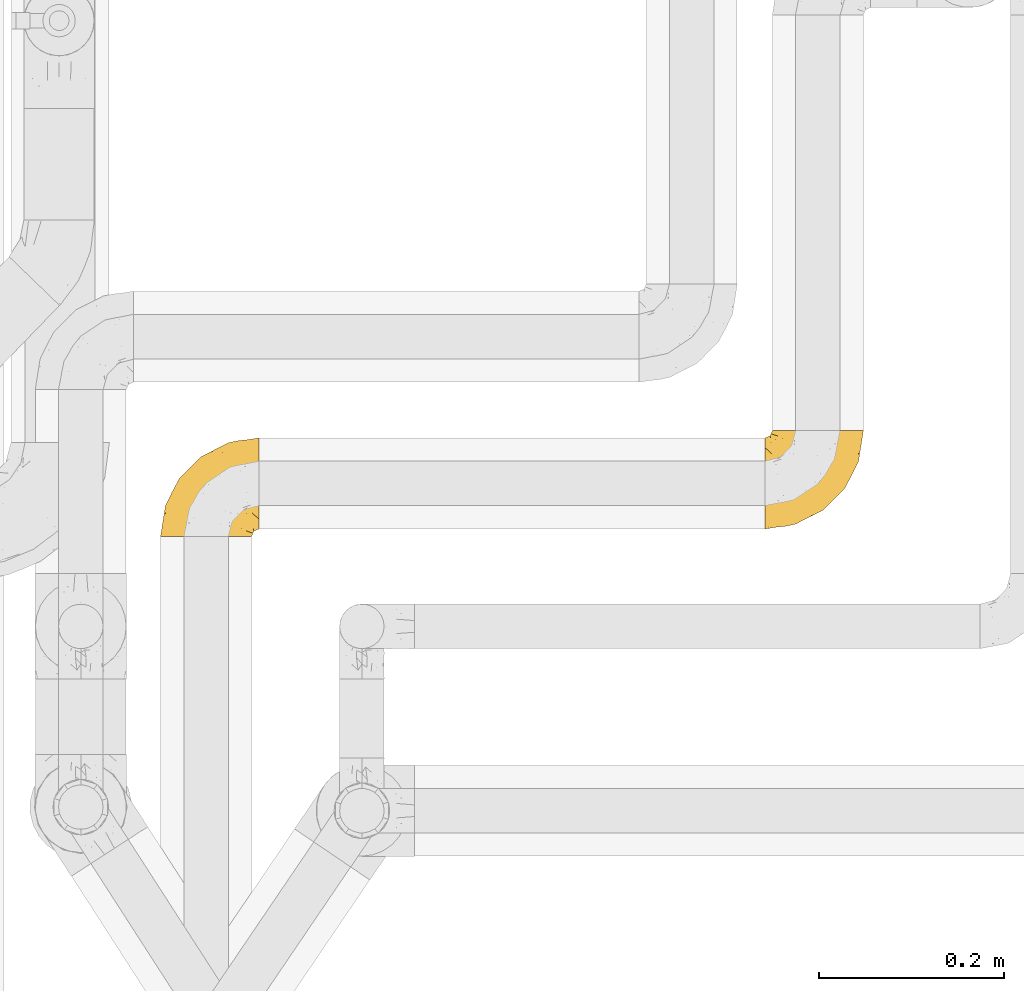
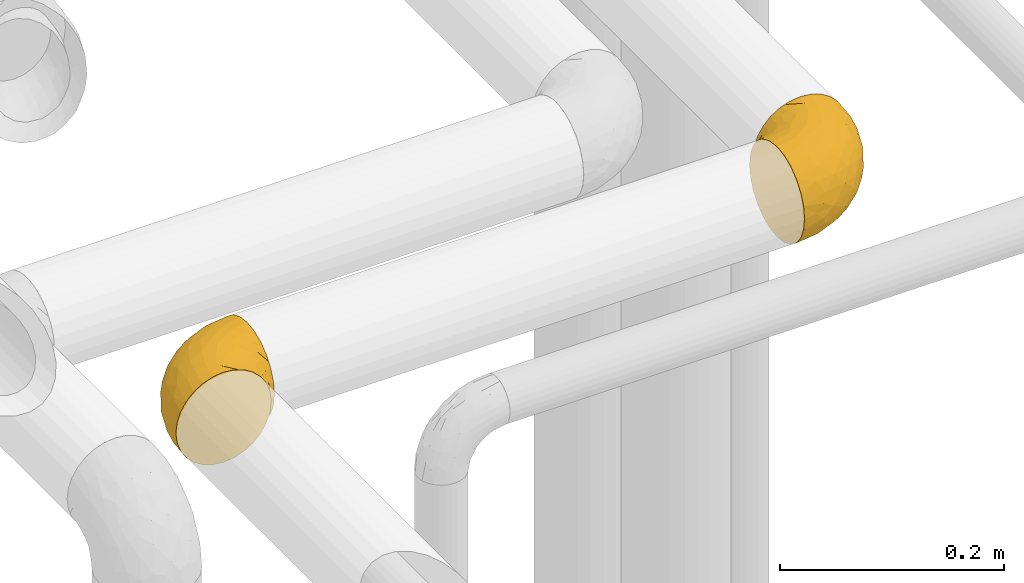
# One storey, part 399 of 827: 2 coverings.
"""IFC2X3 building model written with IfcOpenShell, lengths in millimetres."""

from ifc_helpers import new_model, entity, si_unit, converted_unit, derived_unit, direction, frame, origin, place, context, subcontext, project, spatial, faceted_brep, element, save


model = new_model("IFC2X3")

# Units and contexts
model_context = context("Model", 3, precision=0.01, world=origin(), true_north=direction((6.12303176911189e-17, 1.0)))
body_context = subcontext(model_context, "Body", "Model", "MODEL_VIEW")
ifc_project = project(units=[si_unit("LENGTHUNIT", "METRE", prefix="MILLI"), si_unit("AREAUNIT", "SQUARE_METRE"), si_unit("VOLUMEUNIT", "CUBIC_METRE"), converted_unit("PLANEANGLEUNIT", "DEGREE", entity("IfcRatioMeasure", 0.0174532925199433), si_unit("PLANEANGLEUNIT", "RADIAN"), dimensions=[0, 0, 0, 0, 0, 0, 0]), si_unit("MASSUNIT", "GRAM", prefix="KILO"), derived_unit("MASSDENSITYUNIT", [(si_unit("MASSUNIT", "GRAM", prefix="KILO"), 1), (si_unit("LENGTHUNIT", "METRE"), -3)]), derived_unit("MOMENTOFINERTIAUNIT", [(si_unit("LENGTHUNIT", "METRE"), 4)]), si_unit("TIMEUNIT", "SECOND"), si_unit("FREQUENCYUNIT", "HERTZ"), si_unit("THERMODYNAMICTEMPERATUREUNIT", "DEGREE_CELSIUS"), derived_unit("THERMALTRANSMITTANCEUNIT", [(si_unit("MASSUNIT", "GRAM", prefix="KILO"), 1), (si_unit("THERMODYNAMICTEMPERATUREUNIT", "KELVIN"), -1), (si_unit("TIMEUNIT", "SECOND"), -3)]), derived_unit("VOLUMETRICFLOWRATEUNIT", [(si_unit("LENGTHUNIT", "METRE"), 3), (si_unit("TIMEUNIT", "SECOND"), -1)]), derived_unit("MASSFLOWRATEUNIT", [(si_unit("MASSUNIT", "GRAM", prefix="KILO"), 1), (si_unit("TIMEUNIT", "SECOND"), -1)]), derived_unit("ROTATIONALFREQUENCYUNIT", [(si_unit("TIMEUNIT", "SECOND"), -1)]), si_unit("ELECTRICCURRENTUNIT", "AMPERE"), si_unit("ELECTRICVOLTAGEUNIT", "VOLT"), si_unit("POWERUNIT", "WATT"), si_unit("FORCEUNIT", "NEWTON", prefix="KILO"), si_unit("ILLUMINANCEUNIT", "LUX"), si_unit("LUMINOUSFLUXUNIT", "LUMEN"), si_unit("LUMINOUSINTENSITYUNIT", "CANDELA"), derived_unit("USERDEFINED", [(si_unit("MASSUNIT", "GRAM", prefix="KILO"), -1), (si_unit("LENGTHUNIT", "METRE"), -2), (si_unit("TIMEUNIT", "SECOND"), 3), (si_unit("LUMINOUSFLUXUNIT", "LUMEN"), 1)]), derived_unit("LINEARVELOCITYUNIT", [(si_unit("LENGTHUNIT", "METRE"), 1), (si_unit("TIMEUNIT", "SECOND"), -1)]), si_unit("PRESSUREUNIT", "PASCAL"), derived_unit("USERDEFINED", [(si_unit("LENGTHUNIT", "METRE"), -2), (si_unit("MASSUNIT", "GRAM", prefix="KILO"), 1), (si_unit("TIMEUNIT", "SECOND"), -2)]), derived_unit("LINEARFORCEUNIT", [(si_unit("MASSUNIT", "GRAM", prefix="KILO"), 1), (si_unit("LENGTHUNIT", "METRE"), 1), (si_unit("TIMEUNIT", "SECOND"), -2), (si_unit("LENGTHUNIT", "METRE"), -1)]), derived_unit("PLANARFORCEUNIT", [(si_unit("MASSUNIT", "GRAM", prefix="KILO"), 1), (si_unit("LENGTHUNIT", "METRE"), 1), (si_unit("TIMEUNIT", "SECOND"), -2), (si_unit("LENGTHUNIT", "METRE"), -2)])], contexts=[model_context])

# Site, building, storey
site_placement = place(None, origin())
site = spatial("IfcSite", under=ifc_project, at=site_placement, CompositionType="ELEMENT")
building_placement = place(site_placement, origin())
building = spatial("IfcBuilding", under=site, at=building_placement, CompositionType="ELEMENT")
storey_placement = place(building_placement, frame((0.0, 0.0, 28200.0)))
storey = spatial("IfcBuildingStorey", under=building, at=storey_placement, Name="08", CompositionType="ELEMENT", Elevation=28200.0)

# Coverings
covering_1_placement = place(storey_placement, frame((47429.4, 14538.0, 2949.25)))
element("IfcCovering", 1, at=covering_1_placement, inside=storey, Name=":ADSK_", ObjectType=":ADSK_", PredefinedType="INSULATION", context=body_context, shape_type="Brep", body=[
    faceted_brep([(58.6, 107.75, 99.9), (69.54, 107.75, 98.66), (79.93, 107.75, 95.02), (89.25, 107.75, 89.17), (97.03, 107.75, 81.38), (102.88, 107.75, 72.06), (106.51, 107.75, 61.68), (107.75, 107.75, 50.75), (106.51, 107.75, 39.8), (102.87, 107.75, 29.41), (97.02, 107.75, 20.09), (89.23, 107.75, 12.31), (79.91, 107.75, 6.46), (69.53, 107.75, 2.83), (58.6, 107.75, 1.6), (52.89, 107.75, 2.24), (47.65, 107.75, 2.83), (42.46, 107.75, 4.65), (37.26, 107.75, 6.47), (27.94, 107.75, 12.32), (20.16, 107.75, 20.11), (14.31, 107.75, 29.43), (10.68, 107.75, 39.81), (9.45, 107.75, 50.75), (10.68, 107.75, 61.69), (14.32, 107.75, 72.08), (20.17, 107.75, 81.4), (27.96, 107.75, 89.18), (37.28, 107.75, 95.03), (42.47, 107.75, 96.85), (47.66, 107.75, 98.66), (52.89, 107.75, 99.25), (55.75, 107.75, 99.57), (1.6, 98.22, 38.02), (1.6, 93.31, 26.17), (1.6, 89.4, 21.08), (1.6, 85.5, 15.99), (1.6, 80.41, 12.09), (1.6, 75.32, 8.18), (1.6, 69.39, 5.73), (1.6, 63.47, 3.27), (1.6, 56.48, 2.35), (1.6, 53.61, 1.97), (1.6, 50.75, 1.6), (1.6, 38.02, 3.27), (1.6, 26.17, 8.18), (1.6, 15.99, 15.99), (1.6, 8.18, 26.17), (1.6, 3.27, 38.02), (1.6, 1.6, 50.75), (1.6, 3.27, 63.47), (1.6, 8.18, 75.32), (1.6, 15.99, 85.5), (1.6, 26.17, 93.31), (1.6, 38.02, 98.22), (1.6, 50.75, 99.9), (1.6, 56.48, 99.14), (1.6, 63.47, 98.22), (1.6, 69.39, 95.77), (1.6, 75.32, 93.31), (1.6, 80.41, 89.4), (1.6, 85.5, 85.5), (1.6, 89.4, 80.41), (1.6, 93.31, 75.32), (1.6, 98.22, 63.47), (1.6, 99.9, 50.75), (69.96, 27.53, 59.31), (59.59, 25.32, 73.08), (51.96, 16.29, 63.72), (34.4, 6.79, 50.75), (23.37, 4.51, 58.64), (13.68, 3.51, 50.75), (41.52, 17.47, 76.74), (26.26, 7.6, 67.68), (20.18, 12.27, 78.92), (72.33, 70.89, 94.31), (65.88, 87.17, 98.76), (57.55, 67.3, 98.4), (23.76, 31.65, 94.57), (46.5, 33.58, 89.91), (46.57, 47.23, 96.32), (21.17, 43.26, 98.79), (23.41, 55.08, 99.9), (17.92, 53.99, 99.9), (12.43, 52.9, 99.9), (9.72, 52.36, 99.9), (7.01, 51.82, 99.9), (26.77, 21.5, 87.31), (76.59, 89.94, 95.61), (95.55, 60.45, 60.43), (102.57, 83.0, 65.24), (92.89, 64.79, 72.87), (54.26, 85.93, 99.9), (51.17, 81.31, 99.9), (48.08, 76.69, 99.9), (44.99, 72.06, 99.9), (41.9, 67.44, 99.9), (85.16, 88.74, 90.65), (85.97, 45.98, 63.14), (59.58, 47.13, 91.89), (99.5, 89.4, 75.25), (105.83, 95.66, 50.75), (53.59, 28.5, 82.18), (67.0, 42.81, 85.08), (71.56, 38.28, 76.93), (87.47, 45.35, 50.75), (75.73, 33.61, 50.75), (92.24, 82.57, 83.02), (58.06, 105.04, 99.9), (57.52, 102.33, 99.9), (56.44, 96.91, 99.9), (55.35, 91.42, 99.9), (81.33, 65.92, 87.13), (80.35, 53.11, 80.85), (39.44, 54.37, 99.17), (102.55, 74.94, 50.75), (37.28, 64.35, 99.9), (32.65, 61.26, 99.9), (28.03, 58.17, 99.9), (63.99, 21.87, 50.75), (74.55, 34.79, 67.61), (83.62, 48.48, 72.25), (95.01, 60.15, 50.75), (49.19, 14.33, 50.75), (46.96, 99.07, 98.69), (8.77, 60.55, 99.01), (18.28, 64.18, 98.79), (11.68, 64.36, 98.29), (11.79, 103.17, 68.51), (15.69, 101.69, 76.82), (42.49, 87.75, 98.54), (47.41, 89.38, 99.3), (7.94, 88.34, 83.57), (9.27, 82.14, 89.47), (7.98, 94.51, 75.76), (13.4, 89.64, 84.86), (13.04, 98.41, 75.89), (7.36, 99.71, 64.77), (23.46, 89.37, 90.83), (30.46, 88.21, 94.62), (26.54, 95.2, 90.37), (6.76, 79.14, 91.18), (26.46, 101.22, 88.65), (20.77, 99.41, 84.11), (20.68, 84.72, 91.75), (40.26, 97.47, 96.86), (7.15, 102.19, 50.75), (9.28, 104.02, 58.97), (38.78, 82.66, 98.37), (18.27, 95.42, 83.91), (31.78, 78.67, 97.52), (12.75, 72.69, 95.55), (22.96, 66.46, 98.76), (17.55, 75.3, 95.26), (27.63, 72.74, 98.04), (15.23, 82.93, 90.65), (33.25, 99.27, 93.51), (32.43, 93.51, 94.16), (27.9, 67.35, 99.1), (7.97, 94.51, 25.73), (15.22, 82.94, 10.84), (7.93, 88.33, 17.92), (13.38, 89.64, 16.64), (13.12, 103.62, 30.44), (42.49, 87.74, 2.95), (47.4, 89.38, 2.19), (51.17, 81.31, 1.6), (40.24, 97.47, 4.63), (20.76, 99.41, 17.39), (12.43, 52.9, 1.6), (7.01, 51.82, 1.6), (4.31, 51.28, 1.6), (26.44, 101.21, 12.86), (26.52, 95.19, 11.13), (11.68, 64.36, 3.2), (12.75, 72.69, 5.94), (9.27, 82.13, 12.02), (17.55, 75.3, 6.23), (6.76, 79.14, 10.31), (33.21, 99.28, 8.0), (32.41, 93.51, 7.34), (8.77, 60.55, 2.48), (22.96, 66.46, 2.73), (18.48, 63.96, 2.64), (56.44, 96.91, 1.6), (46.95, 99.06, 2.8), (7.36, 99.7, 36.71), (17.92, 53.99, 1.6), (23.41, 55.08, 1.6), (9.85, 103.3, 38.59), (57.52, 102.33, 1.6), (56.98, 99.62, 1.6), (48.08, 76.69, 1.6), (38.78, 82.66, 3.12), (18.25, 95.42, 17.59), (44.99, 72.06, 1.6), (31.74, 78.68, 3.98), (30.45, 88.2, 6.87), (27.63, 72.75, 3.45), (20.65, 84.74, 9.76), (55.35, 91.42, 1.6), (54.26, 85.93, 1.6), (13.03, 98.41, 25.62), (23.44, 89.37, 10.67), (27.9, 67.35, 2.39), (32.65, 61.26, 1.6), (28.03, 58.17, 1.6), (37.28, 64.35, 1.6), (41.9, 67.44, 1.6), (39.74, 54.08, 2.4), (23.37, 4.51, 42.85), (26.77, 21.5, 14.18), (46.18, 33.43, 11.56), (53.54, 28.5, 19.27), (41.53, 17.47, 24.75), (59.61, 25.36, 28.37), (76.79, 90.18, 5.95), (66.11, 86.97, 2.79), (21.17, 43.26, 2.71), (51.96, 16.29, 37.78), (26.26, 7.6, 33.81), (20.18, 12.27, 22.57), (23.76, 31.65, 6.92), (92.88, 64.79, 28.61), (102.57, 83.0, 36.24), (95.54, 60.44, 41.05), (71.63, 38.35, 24.55), (74.55, 34.8, 33.88), (72.51, 71.54, 7.11), (69.96, 27.53, 42.18), (92.23, 82.57, 18.46), (85.15, 88.74, 10.84), (80.45, 53.19, 20.69), (83.65, 48.49, 29.27), (57.57, 67.28, 3.1), (63.68, 52.32, 9.18), (85.95, 45.94, 38.38), (99.49, 89.4, 26.23), (81.23, 65.75, 14.34), (47.07, 46.73, 5.46), (66.99, 42.82, 16.39)], [[[0, 1, 2, 3, 4, 5, 6, 7, 8, 9, 10, 11, 12, 13, 14, 15, 16, 17, 18, 19, 20, 21, 22, 23, 24, 25, 26, 27, 28, 29, 30, 31, 32]], [[33, 34, 35, 36, 37, 38, 39, 40, 41, 42, 43, 44, 45, 46, 47, 48, 49, 50, 51, 52, 53, 54, 55, 56, 57, 58, 59, 60, 61, 62, 63, 64, 65]], [[66, 67, 68]], [[69, 70, 71]], [[68, 72, 73]], [[73, 72, 74]], [[75, 76, 77]], [[78, 79, 80]], [[51, 50, 73]], [[81, 82, 83, 84, 85, 86, 55]], [[52, 87, 53]], [[74, 52, 51]], [[2, 1, 88]], [[89, 90, 91]], [[77, 92, 93, 94, 95, 96]], [[55, 54, 81]], [[78, 53, 87]], [[5, 90, 6]], [[88, 76, 75]], [[97, 3, 2]], [[89, 91, 98]], [[99, 80, 79]], [[90, 5, 100]], [[74, 87, 52]], [[100, 5, 4]], [[90, 101, 6]], [[79, 102, 103]], [[102, 67, 104]], [[105, 98, 106]], [[107, 4, 3]], [[76, 0, 108, 109, 110, 111, 92]], [[107, 112, 113]], [[114, 77, 96]], [[89, 115, 90]], [[114, 96, 116, 117, 118, 82]], [[75, 97, 88]], [[119, 66, 68]], [[50, 71, 70]], [[100, 91, 90]], [[99, 77, 80]], [[102, 104, 103]], [[97, 107, 3]], [[80, 81, 78]], [[107, 97, 112]], [[68, 73, 70]], [[66, 98, 120]], [[78, 81, 54]], [[114, 81, 80]], [[53, 78, 54]], [[78, 87, 79]], [[102, 87, 72]], [[79, 103, 99]], [[4, 107, 100]], [[91, 100, 107]], [[88, 97, 2]], [[112, 97, 75]], [[99, 112, 75]], [[103, 104, 113]], [[91, 121, 98]], [[89, 105, 122, 115]], [[101, 90, 115]], [[101, 7, 6]], [[88, 1, 76]], [[0, 76, 1]], [[92, 77, 76]], [[73, 74, 51]], [[87, 74, 72]], [[81, 114, 82]], [[77, 114, 80]], [[87, 102, 79]], [[67, 102, 72]], [[68, 67, 72]], [[67, 120, 104]], [[120, 121, 104]], [[104, 121, 113]], [[121, 120, 98]], [[91, 107, 113]], [[91, 113, 121]], [[103, 113, 112]], [[106, 98, 66]], [[105, 89, 98]], [[106, 66, 119]], [[67, 66, 120]], [[68, 69, 123, 119]], [[50, 49, 71]], [[50, 70, 73]], [[112, 99, 103]], [[77, 99, 75]], [[69, 68, 70]], [[29, 124, 110]], [[84, 83, 125]], [[126, 82, 118]], [[59, 58, 127]], [[25, 128, 129]], [[130, 93, 131]], [[132, 62, 133]], [[134, 135, 136]], [[137, 65, 64]], [[64, 134, 137]], [[138, 139, 140]], [[111, 110, 124, 92]], [[134, 136, 137]], [[134, 64, 63]], [[141, 61, 60]], [[125, 58, 57]], [[142, 143, 140]], [[142, 26, 143]], [[127, 83, 82]], [[28, 124, 29]], [[108, 0, 32, 31, 30, 110, 109]], [[30, 29, 110]], [[135, 144, 138]], [[28, 145, 124]], [[57, 56, 55, 86, 85, 84]], [[146, 147, 23]], [[24, 23, 147]], [[25, 143, 26]], [[95, 94, 148]], [[24, 128, 25]], [[149, 138, 143]], [[124, 145, 131]], [[127, 58, 125]], [[150, 148, 139]], [[127, 126, 151]], [[151, 59, 127]], [[152, 151, 126]], [[153, 154, 155]], [[153, 133, 141]], [[145, 28, 27]], [[142, 156, 27]], [[157, 148, 130]], [[61, 133, 62]], [[134, 132, 135]], [[147, 128, 24]], [[65, 137, 146]], [[146, 137, 147]], [[128, 137, 136]], [[137, 128, 147]], [[128, 136, 129]], [[149, 129, 136]], [[25, 129, 143]], [[158, 152, 117]], [[152, 118, 117]], [[153, 151, 152]], [[158, 116, 154]], [[144, 150, 138]], [[153, 152, 158]], [[133, 153, 155]], [[133, 155, 132]], [[60, 151, 141]], [[135, 132, 155]], [[134, 63, 132]], [[144, 135, 155]], [[135, 138, 149]], [[155, 154, 144]], [[150, 154, 96]], [[154, 150, 144]], [[148, 94, 130]], [[82, 126, 127]], [[118, 152, 126]], [[150, 96, 95]], [[139, 148, 157]], [[150, 95, 148]], [[93, 92, 131]], [[130, 145, 156]], [[130, 94, 93]], [[84, 125, 57]], [[127, 125, 83]], [[140, 139, 157]], [[150, 139, 138]], [[140, 157, 142]], [[138, 140, 143]], [[156, 142, 157]], [[27, 26, 142]], [[130, 156, 157]], [[145, 27, 156]], [[132, 63, 62]], [[124, 131, 92]], [[130, 131, 145]], [[129, 149, 143]], [[135, 149, 136]], [[141, 133, 61]], [[60, 59, 151]], [[141, 151, 153]], [[116, 96, 154]], [[153, 158, 154]], [[158, 117, 116]], [[34, 33, 159]], [[160, 161, 162]], [[22, 21, 163]], [[164, 165, 166]], [[19, 18, 167]], [[168, 21, 20]], [[42, 41, 40, 169, 170, 171, 43]], [[172, 173, 168]], [[174, 38, 175]], [[176, 177, 178]], [[179, 164, 180]], [[40, 181, 169]], [[182, 183, 175]], [[17, 184, 185]], [[65, 146, 186]], [[187, 174, 188]], [[23, 22, 189]], [[174, 39, 38]], [[15, 14, 190, 191, 184, 16]], [[181, 40, 39]], [[192, 193, 164]], [[194, 163, 168]], [[33, 186, 159]], [[180, 173, 172]], [[195, 196, 193]], [[18, 185, 167]], [[173, 180, 197]], [[198, 199, 196]], [[200, 201, 185, 184]], [[184, 17, 16]], [[18, 17, 185]], [[202, 159, 186]], [[194, 168, 203]], [[189, 163, 202]], [[204, 205, 182]], [[187, 181, 174]], [[160, 177, 176]], [[206, 183, 182]], [[206, 182, 205]], [[201, 165, 185]], [[165, 164, 167]], [[172, 179, 180]], [[202, 194, 162]], [[176, 161, 160]], [[65, 186, 33]], [[163, 189, 22]], [[175, 177, 182]], [[174, 183, 188]], [[177, 198, 204]], [[199, 160, 162]], [[198, 207, 204]], [[175, 38, 37]], [[198, 177, 160]], [[178, 177, 175]], [[176, 35, 161]], [[34, 159, 161]], [[162, 161, 159]], [[202, 162, 159]], [[199, 162, 203]], [[196, 199, 203]], [[198, 160, 199]], [[193, 197, 180]], [[208, 198, 196]], [[188, 183, 206]], [[175, 183, 174]], [[193, 192, 195]], [[195, 208, 196]], [[197, 196, 203]], [[180, 164, 193]], [[168, 163, 21]], [[166, 165, 201]], [[166, 192, 164]], [[189, 202, 186]], [[186, 146, 189]], [[23, 189, 146]], [[174, 181, 39]], [[169, 181, 187]], [[196, 197, 193]], [[173, 203, 168]], [[203, 173, 197]], [[172, 168, 20]], [[20, 19, 172]], [[179, 172, 19]], [[19, 167, 179]], [[164, 179, 167]], [[35, 176, 36]], [[35, 34, 161]], [[185, 165, 167]], [[162, 194, 203]], [[163, 194, 202]], [[176, 178, 36]], [[37, 36, 178]], [[175, 37, 178]], [[177, 204, 182]], [[207, 198, 208]], [[207, 205, 204]], [[209, 188, 206, 205, 207, 208]], [[48, 210, 71]], [[211, 212, 213]], [[214, 213, 215]], [[216, 217, 13]], [[218, 43, 171, 170, 169, 187, 188]], [[219, 220, 214]], [[47, 46, 221]], [[210, 48, 220]], [[211, 222, 212]], [[222, 45, 44]], [[221, 220, 47]], [[47, 220, 48]], [[221, 211, 214]], [[223, 224, 225]], [[211, 46, 45]], [[226, 227, 215]], [[43, 218, 44]], [[217, 216, 228]], [[219, 215, 229]], [[14, 13, 217]], [[224, 9, 8]], [[10, 230, 11]], [[11, 231, 12]], [[232, 223, 233]], [[234, 208, 195, 192, 166, 201]], [[235, 234, 228]], [[222, 44, 218]], [[106, 229, 236]], [[224, 237, 9]], [[231, 238, 228]], [[9, 237, 10]], [[115, 224, 101]], [[239, 234, 235]], [[231, 11, 230]], [[223, 230, 237]], [[224, 8, 101]], [[223, 236, 233]], [[225, 115, 122, 105]], [[216, 12, 231]], [[209, 234, 239]], [[210, 219, 69]], [[219, 214, 215]], [[229, 119, 219]], [[209, 218, 188]], [[239, 212, 222]], [[239, 222, 218]], [[45, 222, 211]], [[235, 212, 239]], [[213, 212, 240]], [[223, 237, 224]], [[230, 10, 237]], [[238, 231, 230]], [[216, 231, 228]], [[232, 230, 223]], [[235, 238, 240]], [[115, 225, 224]], [[233, 236, 227]], [[8, 7, 101]], [[234, 209, 208]], [[218, 209, 239]], [[217, 228, 234]], [[13, 12, 216]], [[234, 201, 217]], [[217, 201, 200, 184, 191, 190, 14]], [[211, 221, 46]], [[220, 221, 214]], [[71, 210, 69]], [[71, 49, 48]], [[219, 210, 220]], [[226, 215, 213]], [[211, 213, 214]], [[226, 213, 240]], [[215, 227, 229]], [[232, 240, 238]], [[233, 227, 226]], [[232, 233, 226]], [[236, 223, 225]], [[240, 232, 226]], [[232, 238, 230]], [[225, 105, 236]], [[236, 105, 106]], [[236, 229, 227]], [[123, 69, 219, 119]], [[106, 119, 229]], [[238, 235, 228]], [[212, 235, 240]]]),
])
covering_2_placement = place(storey_placement, frame((46777.25, 14530.15, 2949.25)))
element("IfcCovering", 2, at=covering_2_placement, inside=storey, Name=":ADSK_", ObjectType=":ADSK_", PredefinedType="INSULATION", context=body_context, shape_type="Brep", body=[
    faceted_brep([(50.75, 1.6, 99.9), (39.8, 1.6, 98.66), (29.41, 1.6, 95.02), (20.09, 1.6, 89.17), (12.31, 1.6, 81.38), (6.46, 1.6, 72.06), (2.83, 1.6, 61.68), (1.6, 1.6, 50.75), (2.83, 1.6, 39.8), (6.47, 1.6, 29.41), (12.32, 1.6, 20.09), (20.11, 1.6, 12.31), (29.43, 1.6, 6.46), (39.81, 1.6, 2.83), (50.75, 1.6, 1.6), (56.45, 1.6, 2.24), (61.69, 1.6, 2.83), (66.88, 1.6, 4.65), (72.08, 1.6, 6.47), (81.4, 1.6, 12.32), (89.18, 1.6, 20.11), (95.03, 1.6, 29.43), (98.66, 1.6, 39.81), (99.9, 1.6, 50.75), (98.66, 1.6, 61.69), (95.02, 1.6, 72.08), (89.17, 1.6, 81.4), (81.38, 1.6, 89.18), (72.06, 1.6, 95.03), (66.87, 1.6, 96.85), (61.68, 1.6, 98.66), (56.45, 1.6, 99.25), (53.6, 1.6, 99.57), (107.75, 11.12, 38.02), (107.75, 16.03, 26.17), (107.75, 19.94, 21.08), (107.75, 23.84, 15.99), (107.75, 28.93, 12.09), (107.75, 34.02, 8.18), (107.75, 39.95, 5.73), (107.75, 45.87, 3.27), (107.75, 52.86, 2.35), (107.75, 55.73, 1.97), (107.75, 58.6, 1.6), (107.75, 71.32, 3.27), (107.75, 83.17, 8.18), (107.75, 93.35, 15.99), (107.75, 101.16, 26.17), (107.75, 106.07, 38.02), (107.75, 107.75, 50.75), (107.75, 106.07, 63.47), (107.75, 101.16, 75.32), (107.75, 93.35, 85.5), (107.75, 83.17, 93.31), (107.75, 71.32, 98.22), (107.75, 58.6, 99.9), (107.75, 52.86, 99.14), (107.75, 45.87, 98.22), (107.75, 39.95, 95.77), (107.75, 34.02, 93.31), (107.75, 28.93, 89.4), (107.75, 23.84, 85.5), (107.75, 19.94, 80.41), (107.75, 16.03, 75.32), (107.75, 11.12, 63.47), (107.75, 9.45, 50.75), (39.38, 81.82, 59.31), (49.75, 84.02, 73.08), (57.38, 93.05, 63.72), (74.94, 102.55, 50.75), (85.97, 104.83, 58.64), (95.66, 105.83, 50.75), (67.82, 91.87, 76.74), (83.09, 101.74, 67.68), (89.16, 97.07, 78.92), (37.01, 38.45, 94.31), (43.46, 22.17, 98.76), (51.79, 42.04, 98.4), (85.58, 77.69, 94.57), (62.84, 75.76, 89.91), (62.77, 62.11, 96.32), (88.17, 66.08, 98.79), (85.93, 54.26, 99.9), (91.42, 55.35, 99.9), (96.91, 56.44, 99.9), (99.62, 56.98, 99.9), (102.33, 57.52, 99.9), (82.57, 87.84, 87.31), (32.75, 19.41, 95.61), (13.79, 48.89, 60.43), (6.77, 26.34, 65.24), (16.46, 44.55, 72.87), (55.08, 23.41, 99.9), (58.17, 28.03, 99.9), (61.26, 32.65, 99.9), (64.35, 37.28, 99.9), (67.44, 41.9, 99.9), (24.18, 20.6, 90.65), (23.37, 63.36, 63.14), (49.76, 62.21, 91.89), (9.84, 19.94, 75.25), (3.51, 13.68, 50.75), (55.75, 80.85, 82.18), (42.34, 66.53, 85.08), (37.78, 71.06, 76.93), (21.87, 63.99, 50.75), (33.61, 75.73, 50.75), (17.1, 26.77, 83.02), (51.28, 4.31, 99.9), (51.82, 7.01, 99.9), (52.9, 12.43, 99.9), (53.99, 17.92, 99.9), (28.01, 43.43, 87.13), (28.99, 56.23, 80.85), (69.9, 54.97, 99.17), (6.79, 34.4, 50.75), (72.06, 44.99, 99.9), (76.69, 48.08, 99.9), (81.31, 51.17, 99.9), (45.35, 87.47, 50.75), (34.79, 74.55, 67.61), (25.72, 60.86, 72.25), (14.33, 49.19, 50.75), (60.15, 95.01, 50.75), (62.38, 10.27, 98.69), (100.57, 48.79, 99.01), (91.06, 45.16, 98.79), (97.66, 44.99, 98.29), (97.55, 6.17, 68.51), (93.65, 7.65, 76.82), (66.85, 21.59, 98.54), (61.93, 19.96, 99.3), (101.4, 21.0, 83.57), (100.07, 27.2, 89.47), (101.36, 14.83, 75.76), (95.94, 19.7, 84.86), (96.3, 10.93, 75.89), (101.98, 9.63, 64.77), (85.88, 19.97, 90.83), (78.88, 21.13, 94.62), (82.8, 14.14, 90.37), (102.58, 30.2, 91.18), (82.88, 8.12, 88.65), (88.57, 9.93, 84.11), (88.67, 24.62, 91.75), (69.08, 11.87, 96.86), (102.19, 7.15, 50.75), (100.06, 5.32, 58.97), (70.56, 26.68, 98.37), (91.07, 13.92, 83.91), (77.56, 30.67, 97.52), (96.59, 36.65, 95.55), (86.38, 42.89, 98.76), (91.79, 34.04, 95.26), (81.71, 36.6, 98.04), (94.11, 26.41, 90.65), (76.09, 10.07, 93.51), (76.91, 15.83, 94.16), (81.44, 41.99, 99.1), (101.37, 14.83, 25.73), (94.12, 26.4, 10.84), (101.41, 21.01, 17.92), (95.96, 19.71, 16.64), (96.22, 5.72, 30.44), (66.85, 21.6, 2.95), (61.94, 19.96, 2.19), (58.17, 28.03, 1.6), (69.1, 11.87, 4.63), (88.58, 9.93, 17.39), (96.91, 56.44, 1.6), (102.33, 57.52, 1.6), (105.04, 58.06, 1.6), (82.9, 8.13, 12.86), (82.82, 14.15, 11.13), (97.66, 44.99, 3.2), (96.59, 36.65, 5.94), (100.07, 27.21, 12.02), (91.79, 34.04, 6.23), (102.58, 30.2, 10.31), (76.13, 10.06, 8.0), (76.93, 15.83, 7.34), (100.57, 48.79, 2.48), (86.38, 42.89, 2.73), (90.86, 45.38, 2.64), (52.9, 12.43, 1.6), (62.39, 10.28, 2.8), (101.98, 9.64, 36.71), (91.42, 55.35, 1.6), (85.93, 54.26, 1.6), (99.49, 6.05, 38.59), (51.82, 7.01, 1.6), (52.36, 9.72, 1.6), (61.26, 32.65, 1.6), (70.56, 26.68, 3.12), (91.09, 13.92, 17.59), (64.35, 37.28, 1.6), (77.6, 30.66, 3.98), (78.89, 21.14, 6.87), (81.71, 36.59, 3.45), (88.69, 24.6, 9.76), (53.99, 17.92, 1.6), (55.08, 23.41, 1.6), (96.31, 10.93, 25.62), (85.9, 19.97, 10.67), (81.45, 41.99, 2.39), (76.69, 48.08, 1.6), (81.31, 51.17, 1.6), (72.06, 44.99, 1.6), (67.44, 41.9, 1.6), (69.6, 55.26, 2.4), (85.97, 104.83, 42.85), (82.57, 87.84, 14.18), (63.16, 75.91, 11.56), (55.81, 80.84, 19.27), (67.81, 91.87, 24.75), (49.73, 83.98, 28.37), (32.55, 19.16, 5.95), (43.23, 22.37, 2.79), (88.17, 66.08, 2.71), (57.38, 93.05, 37.78), (83.08, 101.74, 33.81), (89.16, 97.07, 22.57), (85.58, 77.69, 6.92), (16.46, 44.55, 28.61), (6.77, 26.34, 36.24), (13.8, 48.9, 41.05), (37.71, 70.99, 24.55), (34.8, 74.55, 33.88), (36.83, 37.8, 7.11), (39.38, 81.82, 42.18), (17.12, 26.77, 18.46), (24.19, 20.6, 10.84), (28.89, 56.15, 20.69), (25.69, 60.85, 29.27), (51.77, 42.06, 3.1), (45.66, 57.03, 9.18), (23.39, 63.4, 38.38), (9.85, 19.94, 26.23), (28.11, 43.59, 14.34), (62.27, 62.61, 5.46), (42.35, 66.52, 16.39)], [[[0, 1, 2, 3, 4, 5, 6, 7, 8, 9, 10, 11, 12, 13, 14, 15, 16, 17, 18, 19, 20, 21, 22, 23, 24, 25, 26, 27, 28, 29, 30, 31, 32]], [[33, 34, 35, 36, 37, 38, 39, 40, 41, 42, 43, 44, 45, 46, 47, 48, 49, 50, 51, 52, 53, 54, 55, 56, 57, 58, 59, 60, 61, 62, 63, 64, 65]], [[66, 67, 68]], [[69, 70, 71]], [[68, 72, 73]], [[73, 72, 74]], [[75, 76, 77]], [[78, 79, 80]], [[51, 50, 73]], [[81, 82, 83, 84, 85, 86, 55]], [[52, 87, 53]], [[74, 52, 51]], [[2, 1, 88]], [[89, 90, 91]], [[77, 92, 93, 94, 95, 96]], [[55, 54, 81]], [[78, 53, 87]], [[5, 90, 6]], [[88, 76, 75]], [[97, 3, 2]], [[89, 91, 98]], [[99, 80, 79]], [[90, 5, 100]], [[74, 87, 52]], [[100, 5, 4]], [[90, 101, 6]], [[79, 102, 103]], [[102, 67, 104]], [[105, 98, 106]], [[107, 4, 3]], [[76, 0, 108, 109, 110, 111, 92]], [[107, 112, 113]], [[114, 77, 96]], [[89, 115, 90]], [[114, 96, 116, 117, 118, 82]], [[75, 97, 88]], [[119, 66, 68]], [[50, 71, 70]], [[100, 91, 90]], [[99, 77, 80]], [[102, 104, 103]], [[97, 107, 3]], [[80, 81, 78]], [[107, 97, 112]], [[68, 73, 70]], [[66, 98, 120]], [[78, 81, 54]], [[114, 81, 80]], [[53, 78, 54]], [[78, 87, 79]], [[102, 87, 72]], [[79, 103, 99]], [[4, 107, 100]], [[91, 100, 107]], [[88, 97, 2]], [[112, 97, 75]], [[99, 112, 75]], [[103, 104, 113]], [[91, 121, 98]], [[89, 105, 122, 115]], [[101, 90, 115]], [[101, 7, 6]], [[88, 1, 76]], [[0, 76, 1]], [[92, 77, 76]], [[73, 74, 51]], [[87, 74, 72]], [[81, 114, 82]], [[77, 114, 80]], [[87, 102, 79]], [[67, 102, 72]], [[68, 67, 72]], [[67, 120, 104]], [[120, 121, 104]], [[104, 121, 113]], [[121, 120, 98]], [[91, 107, 113]], [[91, 113, 121]], [[103, 113, 112]], [[106, 98, 66]], [[105, 89, 98]], [[106, 66, 119]], [[67, 66, 120]], [[68, 69, 123, 119]], [[50, 49, 71]], [[50, 70, 73]], [[112, 99, 103]], [[77, 99, 75]], [[69, 68, 70]], [[29, 124, 110]], [[84, 83, 125]], [[126, 82, 118]], [[59, 58, 127]], [[25, 128, 129]], [[130, 93, 131]], [[132, 62, 133]], [[134, 135, 136]], [[137, 65, 64]], [[64, 134, 137]], [[138, 139, 140]], [[111, 110, 124, 92]], [[134, 136, 137]], [[134, 64, 63]], [[141, 61, 60]], [[125, 58, 57]], [[142, 143, 140]], [[142, 26, 143]], [[127, 83, 82]], [[28, 124, 29]], [[108, 0, 32, 31, 30, 110, 109]], [[30, 29, 110]], [[135, 144, 138]], [[28, 145, 124]], [[57, 56, 55, 86, 85, 84]], [[146, 147, 23]], [[24, 23, 147]], [[25, 143, 26]], [[95, 94, 148]], [[24, 128, 25]], [[149, 138, 143]], [[124, 145, 131]], [[127, 58, 125]], [[150, 148, 139]], [[127, 126, 151]], [[151, 59, 127]], [[152, 151, 126]], [[153, 154, 155]], [[153, 133, 141]], [[145, 28, 27]], [[142, 156, 27]], [[157, 148, 130]], [[61, 133, 62]], [[134, 132, 135]], [[147, 128, 24]], [[65, 137, 146]], [[146, 137, 147]], [[128, 137, 136]], [[137, 128, 147]], [[128, 136, 129]], [[149, 129, 136]], [[25, 129, 143]], [[158, 152, 117]], [[152, 118, 117]], [[153, 151, 152]], [[158, 116, 154]], [[144, 150, 138]], [[153, 152, 158]], [[133, 153, 155]], [[133, 155, 132]], [[60, 151, 141]], [[135, 132, 155]], [[134, 63, 132]], [[144, 135, 155]], [[135, 138, 149]], [[155, 154, 144]], [[150, 154, 96]], [[154, 150, 144]], [[148, 94, 130]], [[82, 126, 127]], [[118, 152, 126]], [[150, 96, 95]], [[139, 148, 157]], [[150, 95, 148]], [[93, 92, 131]], [[130, 145, 156]], [[130, 94, 93]], [[84, 125, 57]], [[127, 125, 83]], [[140, 139, 157]], [[150, 139, 138]], [[140, 157, 142]], [[138, 140, 143]], [[156, 142, 157]], [[27, 26, 142]], [[130, 156, 157]], [[145, 27, 156]], [[132, 63, 62]], [[124, 131, 92]], [[130, 131, 145]], [[129, 149, 143]], [[135, 149, 136]], [[141, 133, 61]], [[60, 59, 151]], [[141, 151, 153]], [[116, 96, 154]], [[153, 158, 154]], [[158, 117, 116]], [[34, 33, 159]], [[160, 161, 162]], [[22, 21, 163]], [[164, 165, 166]], [[19, 18, 167]], [[168, 21, 20]], [[42, 41, 40, 169, 170, 171, 43]], [[172, 173, 168]], [[174, 38, 175]], [[176, 177, 178]], [[179, 164, 180]], [[40, 181, 169]], [[182, 183, 175]], [[17, 184, 185]], [[65, 146, 186]], [[187, 174, 188]], [[23, 22, 189]], [[174, 39, 38]], [[15, 14, 190, 191, 184, 16]], [[181, 40, 39]], [[192, 193, 164]], [[194, 163, 168]], [[33, 186, 159]], [[180, 173, 172]], [[195, 196, 193]], [[18, 185, 167]], [[173, 180, 197]], [[198, 199, 196]], [[200, 201, 185, 184]], [[184, 17, 16]], [[18, 17, 185]], [[202, 159, 186]], [[194, 168, 203]], [[189, 163, 202]], [[204, 205, 182]], [[187, 181, 174]], [[160, 177, 176]], [[206, 183, 182]], [[206, 182, 205]], [[201, 165, 185]], [[165, 164, 167]], [[172, 179, 180]], [[202, 194, 162]], [[176, 161, 160]], [[65, 186, 33]], [[163, 189, 22]], [[175, 177, 182]], [[174, 183, 188]], [[177, 198, 204]], [[199, 160, 162]], [[198, 207, 204]], [[175, 38, 37]], [[198, 177, 160]], [[178, 177, 175]], [[176, 35, 161]], [[34, 159, 161]], [[162, 161, 159]], [[202, 162, 159]], [[199, 162, 203]], [[196, 199, 203]], [[198, 160, 199]], [[193, 197, 180]], [[208, 198, 196]], [[188, 183, 206]], [[175, 183, 174]], [[193, 192, 195]], [[195, 208, 196]], [[197, 196, 203]], [[180, 164, 193]], [[168, 163, 21]], [[166, 165, 201]], [[166, 192, 164]], [[189, 202, 186]], [[186, 146, 189]], [[23, 189, 146]], [[174, 181, 39]], [[169, 181, 187]], [[196, 197, 193]], [[173, 203, 168]], [[203, 173, 197]], [[172, 168, 20]], [[20, 19, 172]], [[179, 172, 19]], [[19, 167, 179]], [[164, 179, 167]], [[35, 176, 36]], [[35, 34, 161]], [[185, 165, 167]], [[162, 194, 203]], [[163, 194, 202]], [[176, 178, 36]], [[37, 36, 178]], [[175, 37, 178]], [[177, 204, 182]], [[207, 198, 208]], [[207, 205, 204]], [[209, 188, 206, 205, 207, 208]], [[48, 210, 71]], [[211, 212, 213]], [[214, 213, 215]], [[216, 217, 13]], [[218, 43, 171, 170, 169, 187, 188]], [[219, 220, 214]], [[47, 46, 221]], [[210, 48, 220]], [[211, 222, 212]], [[222, 45, 44]], [[221, 220, 47]], [[47, 220, 48]], [[221, 211, 214]], [[223, 224, 225]], [[211, 46, 45]], [[226, 227, 215]], [[43, 218, 44]], [[217, 216, 228]], [[219, 215, 229]], [[14, 13, 217]], [[224, 9, 8]], [[10, 230, 11]], [[11, 231, 12]], [[232, 223, 233]], [[234, 208, 195, 192, 166, 201]], [[235, 234, 228]], [[222, 44, 218]], [[106, 229, 236]], [[224, 237, 9]], [[231, 238, 228]], [[9, 237, 10]], [[115, 224, 101]], [[239, 234, 235]], [[231, 11, 230]], [[223, 230, 237]], [[224, 8, 101]], [[223, 236, 233]], [[225, 115, 122, 105]], [[216, 12, 231]], [[209, 234, 239]], [[210, 219, 69]], [[219, 214, 215]], [[229, 119, 219]], [[209, 218, 188]], [[239, 212, 222]], [[239, 222, 218]], [[45, 222, 211]], [[235, 212, 239]], [[213, 212, 240]], [[223, 237, 224]], [[230, 10, 237]], [[238, 231, 230]], [[216, 231, 228]], [[232, 230, 223]], [[235, 238, 240]], [[115, 225, 224]], [[233, 236, 227]], [[8, 7, 101]], [[234, 209, 208]], [[218, 209, 239]], [[217, 228, 234]], [[13, 12, 216]], [[234, 201, 217]], [[217, 201, 200, 184, 191, 190, 14]], [[211, 221, 46]], [[220, 221, 214]], [[71, 210, 69]], [[71, 49, 48]], [[219, 210, 220]], [[226, 215, 213]], [[211, 213, 214]], [[226, 213, 240]], [[215, 227, 229]], [[232, 240, 238]], [[233, 227, 226]], [[232, 233, 226]], [[236, 223, 225]], [[240, 232, 226]], [[232, 238, 230]], [[225, 105, 236]], [[236, 105, 106]], [[236, 229, 227]], [[123, 69, 219, 119]], [[106, 119, 229]], [[238, 235, 228]], [[212, 235, 240]]]),
])

save(model, "model.ifc")
